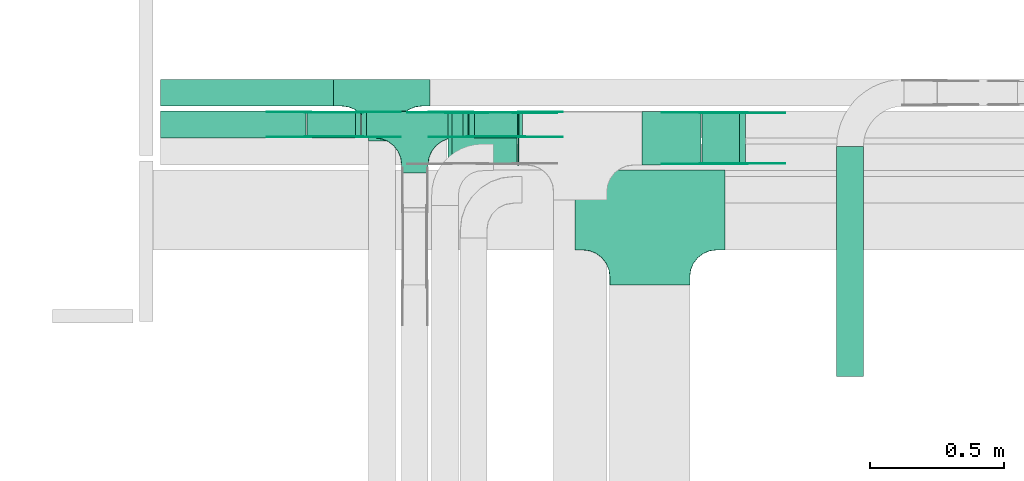
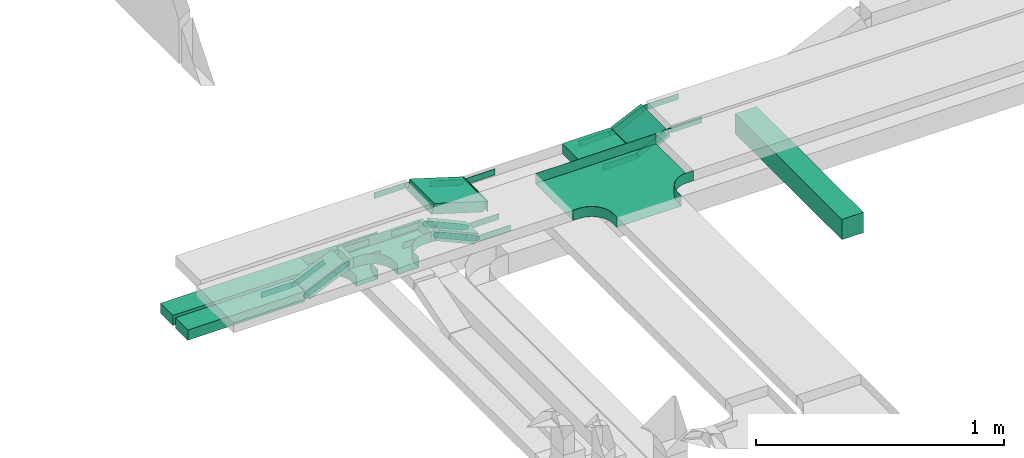
# One storey, part 7 of 19: 31 flow fittings, 11 flow segments.
"""IFC2X3 building model written with IfcOpenShell, lengths in millimetres."""

from ifc_helpers import new_model, entity, si_unit, converted_unit, derived_unit, direction, frame, frame_2d, origin, origin_2d_with_axis, place, context, subcontext, project, spatial, polyline, circle_curve, parameter, trimmed, segment, composite_curve, rectangle, outline, extrude, faceted_brep, source, transform, mapped, material, type_object, type_shapes, element, save


model = new_model("IFC2X3")

# Units and contexts
model_context = context("Model", 3, precision=0.01, world=origin(), true_north=direction((6.12303176911189e-17, 1.0)))
body_context = subcontext(model_context, "Body", "Model", "MODEL_VIEW")
ifc_project = project(units=[si_unit("LENGTHUNIT", "METRE", prefix="MILLI"), si_unit("AREAUNIT", "SQUARE_METRE"), si_unit("VOLUMEUNIT", "CUBIC_METRE"), converted_unit("PLANEANGLEUNIT", "DEGREE", entity("IfcRatioMeasure", 0.0174532925199433), si_unit("PLANEANGLEUNIT", "RADIAN"), dimensions=[0, 0, 0, 0, 0, 0, 0]), si_unit("MASSUNIT", "GRAM", prefix="KILO"), derived_unit("MASSDENSITYUNIT", [(si_unit("MASSUNIT", "GRAM", prefix="KILO"), 1), (si_unit("LENGTHUNIT", "METRE"), -3)]), derived_unit("MOMENTOFINERTIAUNIT", [(si_unit("LENGTHUNIT", "METRE"), 4)]), si_unit("TIMEUNIT", "SECOND"), si_unit("FREQUENCYUNIT", "HERTZ"), si_unit("THERMODYNAMICTEMPERATUREUNIT", "DEGREE_CELSIUS"), derived_unit("THERMALTRANSMITTANCEUNIT", [(si_unit("MASSUNIT", "GRAM", prefix="KILO"), 1), (si_unit("THERMODYNAMICTEMPERATUREUNIT", "KELVIN"), -1), (si_unit("TIMEUNIT", "SECOND"), -3)]), derived_unit("VOLUMETRICFLOWRATEUNIT", [(si_unit("LENGTHUNIT", "METRE"), 3), (si_unit("TIMEUNIT", "SECOND"), -1)]), derived_unit("MASSFLOWRATEUNIT", [(si_unit("MASSUNIT", "GRAM", prefix="KILO"), 1), (si_unit("TIMEUNIT", "SECOND"), -1)]), derived_unit("ROTATIONALFREQUENCYUNIT", [(si_unit("TIMEUNIT", "SECOND"), -1)]), si_unit("ELECTRICCURRENTUNIT", "AMPERE"), si_unit("ELECTRICVOLTAGEUNIT", "VOLT"), si_unit("POWERUNIT", "WATT"), si_unit("FORCEUNIT", "NEWTON", prefix="KILO"), si_unit("ILLUMINANCEUNIT", "LUX"), si_unit("LUMINOUSFLUXUNIT", "LUMEN"), si_unit("LUMINOUSINTENSITYUNIT", "CANDELA"), derived_unit("USERDEFINED", [(si_unit("MASSUNIT", "GRAM", prefix="KILO"), -1), (si_unit("LENGTHUNIT", "METRE"), -2), (si_unit("TIMEUNIT", "SECOND"), 3), (si_unit("LUMINOUSFLUXUNIT", "LUMEN"), 1)]), derived_unit("LINEARVELOCITYUNIT", [(si_unit("LENGTHUNIT", "METRE"), 1), (si_unit("TIMEUNIT", "SECOND"), -1)]), si_unit("PRESSUREUNIT", "PASCAL"), derived_unit("USERDEFINED", [(si_unit("LENGTHUNIT", "METRE"), -2), (si_unit("MASSUNIT", "GRAM", prefix="KILO"), 1), (si_unit("TIMEUNIT", "SECOND"), -2)]), derived_unit("LINEARFORCEUNIT", [(si_unit("MASSUNIT", "GRAM", prefix="KILO"), 1), (si_unit("LENGTHUNIT", "METRE"), 1), (si_unit("TIMEUNIT", "SECOND"), -2), (si_unit("LENGTHUNIT", "METRE"), -1)]), derived_unit("PLANARFORCEUNIT", [(si_unit("MASSUNIT", "GRAM", prefix="KILO"), 1), (si_unit("LENGTHUNIT", "METRE"), 1), (si_unit("TIMEUNIT", "SECOND"), -2), (si_unit("LENGTHUNIT", "METRE"), -2)])], contexts=[model_context])

# Site, building, storey
site_placement = place(None, frame((0.0, -0.00077364408347762, 0.0)))
site = spatial("IfcSite", under=ifc_project, at=site_placement, CompositionType="ELEMENT")
building_placement = place(site_placement, origin())
building = spatial("IfcBuilding", under=site, at=building_placement, CompositionType="ELEMENT")
storey_placement = place(building_placement, frame((0.0, 0.0, 12000.0)))
storey = spatial("IfcBuildingStorey", under=building, at=storey_placement, CompositionType="ELEMENT", Elevation=12000.0)

# Flow segments
cable_carrier_segment_type = type_object("IfcCableCarrierSegmentType", PredefinedType="CABLETRAYSEGMENT")
flow_segment_1_placement = place(storey_placement, frame((16550.9424818654, 14792.4967897, 2500.0)))
element("IfcFlowSegment", 1, at=flow_segment_1_placement, inside=storey, type_object=cable_carrier_segment_type, context=body_context, shape_type="SweptSolid", body=[
    extrude(rectangle(XDim=646.818670860271, YDim=99.9999999999989, at=frame_2d((-2.1600499167107e-12, 0.0), x_axis=(1.0, 0.0))), frame((323.409335430133, 50.0, 0.0), z_axis=(0.0, 0.0, 1.0), x_axis=(-1.0, 0.0, 0.0)), (0.0, 0.0, 1.0), 50.0000000000016),
])
flow_segment_2_placement = place(storey_placement, frame((17702.9651681534, 14673.6298749258, 2505.07528193029)))
element("IfcFlowSegment", 2, at=flow_segment_2_placement, inside=storey, type_object=cable_carrier_segment_type, context=body_context, shape_type="SweptSolid", body=[
    extrude(rectangle(XDim=50.0000000000028, YDim=99.9999999999989, at=origin_2d_with_axis()), frame((10.1684160768604, 50.0, 103.1427625712), z_axis=(0.913545457643227, 0.0, -0.406736643074393), x_axis=(0.406736643074393, 0.0, 0.913545457643227)), (0.0, 0.0, 1.0), 197.435189323302),
])
flow_segment_3_placement = place(storey_placement, frame((16550.9424818654, 14673.6298749258, 2500.0)))
element("IfcFlowSegment", 3, at=flow_segment_3_placement, inside=storey, type_object=cable_carrier_segment_type, context=body_context, shape_type="SweptSolid", body=[
    extrude(rectangle(XDim=543.455150568502, YDim=99.9999999999989, at=frame_2d((-1.08002495835535e-12, 0.0), x_axis=(1.0, 0.0))), frame((271.72757528425, 50.0, 0.0), z_axis=(0.0, 0.0, 1.0), x_axis=(-1.0, 0.0, 0.0)), (0.0, 0.0, 1.0), 49.9999999999995),
])
flow_segment_4_placement = place(storey_placement, frame((17680.803072578, 14673.6298749258, 2586.13196287297)))
element("IfcFlowSegment", 4, at=flow_segment_4_placement, inside=storey, type_object=cable_carrier_segment_type, context=body_context, shape_type="SweptSolid", body=[
    extrude(rectangle(XDim=18.6216035453551, YDim=99.9999999999989, at=frame_2d((-1.08357767203415e-12, 0.0), x_axis=(1.0, 0.0))), frame((9.31080177267646, 50.0, 0.0), z_axis=(0.0, 0.0, 1.0), x_axis=(-1.0, 0.0, 0.0)), (0.0, 0.0, 1.0), 50.0000000000016),
])
flow_segment_5_placement = place(storey_placement, frame((18573.0842066979, 14572.4967897, 2733.33230167144)))
element("IfcFlowSegment", 5, at=flow_segment_5_placement, inside=storey, type_object=cable_carrier_segment_type, context=body_context, shape_type="SweptSolid", body=[
    extrude(rectangle(XDim=49.9999999999998, YDim=155.862434681128, at=frame_2d((9.80548975348938e-13, 4.56523707725864e-13), x_axis=(0.0, 1.0))), frame((81.195125672565, 0.0, 55.5928502834292), z_axis=(0.0, 1.0, 0.0), x_axis=(-0.90630778703871, 0.0, -0.422618261736281)), (0.0, 0.0, 1.0), 200.000000000002),
])
flow_segment_6_placement = place(storey_placement, frame((17884.8247086532, 14572.4967897, 2727.85030390974)))
element("IfcFlowSegment", 6, at=flow_segment_6_placement, inside=storey, type_object=cable_carrier_segment_type, context=body_context, shape_type="SweptSolid", body=[
    extrude(rectangle(XDim=3.76271822263056, YDim=200.000000000002, at=frame_2d((-1.08291153821938e-12, 2.16715534406831e-12), x_axis=(1.0, 0.0))), frame((1.88135911131636, 100.0, 0.0), z_axis=(0.0, 0.0, 1.0), x_axis=(-1.0, 0.0, 0.0)), (0.0, 0.0, 1.0), 50.0000000000016),
])
flow_segment_7_placement = place(storey_placement, frame((17624.0602118023, 14572.4967897, 2730.5022187924)))
element("IfcFlowSegment", 7, at=flow_segment_7_placement, inside=storey, type_object=cable_carrier_segment_type, context=body_context, shape_type="SweptSolid", body=[
    extrude(rectangle(XDim=50.0000000000004, YDim=200.000000000002, at=frame_2d((0.0, 2.16715534406831e-12), x_axis=(1.0, 0.0))), frame((7.30929261783618, 100.0, 98.2063258045626), z_axis=(0.956304755965903, 0.0, -0.292371704713358), x_axis=(0.292371704713358, 0.0, 0.956304755965903)), (0.0, 0.0, 1.0), 254.124136185707),
])
flow_segment_8_placement = place(storey_placement, frame((18348.5874268759, 14572.4967897, 2727.85030390974)))
element("IfcFlowSegment", 8, at=flow_segment_8_placement, inside=storey, type_object=cable_carrier_segment_type, context=body_context, shape_type="SweptSolid", body=[
    extrude(rectangle(XDim=220.899998987963, YDim=200.000000000002, at=frame_2d((0.0, 2.16715534406831e-12), x_axis=(1.0, 0.0))), frame((110.449999493981, 100.0, 0.0), z_axis=(0.0, 0.0, 1.0), x_axis=(-1.0, 0.0, 0.0)), (0.0, 0.0, 1.0), 50.0000000000016),
])
flow_segment_9_placement = place(storey_placement, frame((19076.5152668448, 13782.4967897, 2650.0)))
element("IfcFlowSegment", 9, at=flow_segment_9_placement, inside=storey, type_object=cable_carrier_segment_type, context=body_context, shape_type="SweptSolid", body=[
    extrude(rectangle(XDim=859.000000000028, YDim=99.9999999999989, at=origin_2d_with_axis()), frame((50.0, 429.500000000015, 0.0), z_axis=(0.0, 0.0, 1.0), x_axis=(0.0, -1.0, 0.0)), (0.0, 0.0, 1.0), 99.9999999999989),
])
flow_segment_10_placement = place(storey_placement, frame((17097.9381244638, 14673.6298749258, 2505.07528193054)))
element("IfcFlowSegment", 10, at=flow_segment_10_placement, inside=storey, type_object=cable_carrier_segment_type, context=body_context, shape_type="SweptSolid", body=[
    extrude(rectangle(XDim=49.9999999999993, YDim=99.9999999999989, at=frame_2d((0.0, 0.0), x_axis=(0.0, 1.0))), frame((10.1684160768561, 50.0, 22.838636441082), z_axis=(0.913545457643292, 0.0, 0.406736643074248), x_axis=(0.0, 1.0, 0.0)), (0.0, 0.0, 1.0), 197.435189322844),
])
flow_segment_11_placement = place(storey_placement, frame((17302.1814690323, 14673.6298749258, 2586.13196287297)))
element("IfcFlowSegment", 11, at=flow_segment_11_placement, inside=storey, type_object=cable_carrier_segment_type, context=body_context, shape_type="SweptSolid", body=[
    extrude(rectangle(XDim=18.6216035457038, YDim=99.9999999999989, at=origin_2d_with_axis()), frame((9.31080177285189, 50.0, 0.0)), (0.0, 0.0, 1.0), 50.0000000000016),
])

# Flow fittings
ifc_material_1 = material()
cable_carrier_fitting_type_1 = type_object("IfcCableCarrierFittingType", PredefinedType="NOTDEFINED", material=ifc_material_1)
shared_shape_1 = source(origin(), body_context, "Body", "Brep", [
    faceted_brep([(-53.4074173710859, -124.118095489752, 25.0), (-50.0, -150.0, 25.0), (-50.0, -180.0, 25.0), (-49.1999999999934, -180.0, 25.0), (-49.1999999999926, -150.0, 25.0), (-52.6346767100545, -123.91104025367, 25.0), (-62.7046392985216, -99.6000000000037, 25.0), (-78.7236364563899, -78.7236364563991, 25.0), (-99.5999999999949, -62.7046392985315, 25.0), (-123.911040253662, -52.6346767100651, 25.0), (-150.0, -49.2000000000047, 25.0), (-180.0, -49.2000000000047, 25.0), (-180.0, -50.0, 25.0), (-150.0, -50.0, 25.0), (-124.118095489745, -53.4074173710983, 25.0), (-100.0, -63.3974596215602, 25.0), (-79.2893218813398, -79.2893218813488, 25.0), (-63.3974596215496, -100.0, 25.0), (180.0, -50.0, 25.0), (180.0, -49.2000000000047, 25.0), (150.0, -49.2000000000046, 25.0), (123.911040253717, -52.634676710066, 25.0), (99.6000000000452, -62.7046392985316, 25.0), (78.7236364564342, -78.7236364563979, 25.0), (62.7046392985581, -99.6000000000012, 25.0), (52.6346767100809, -123.911040253668, 25.0), (49.200000000007, -150.0, 25.0), (49.2000000000071, -180.0, 25.0), (50.0, -180.0, 25.0), (50.0, -150.0, 25.0), (53.4074173711136, -124.11809548975, 25.0), (63.3974596215874, -100.0, 25.0), (79.2893218813853, -79.2893218813486, 25.0), (100.0, -63.3974596215613, 25.0), (124.1180954898, -53.4074173710999, 25.0), (150.0, -50.0, 25.0), (180.0, 49.1999999999958, 25.0), (180.0, 50.0, 25.0), (-180.0, 50.0, 25.0), (-180.0, 49.1999999999958, 25.0), (-180.0, -50.0, -25.0), (-180.0, 50.0, -25.0), (180.0, 50.0, -25.0), (180.0, -50.0, -25.0), (150.0, -50.0, -25.0), (124.1180954898, -53.4074173710999, -25.0), (100.0, -63.3974596215613, -25.0), (79.2893218813853, -79.2893218813486, -25.0), (63.3974596215874, -100.0, -25.0), (53.4074173711136, -124.11809548975, -25.0), (50.0, -150.0, -25.0), (50.0, -180.0, -25.0), (-50.0, -180.0, -25.0), (-50.0, -150.0, -25.0), (-53.4074173710859, -124.118095489752, -25.0), (-63.3974596215496, -100.0, -25.0), (-79.2893218813398, -79.2893218813488, -25.0), (-100.0, -63.3974596215602, -25.0), (-124.118095489745, -53.4074173710983, -25.0), (-150.0, -50.0, -25.0), (-50.0, -150.0, -24.199999999986), (49.2000000000071, -180.0, -24.199999999986), (-49.1999999999934, -180.0, -24.199999999986), (-49.1999999999926, -150.0, -24.199999999986), (-150.0, -49.2000000000047, -24.199999999986), (-180.0, -49.2000000000047, -24.199999999986), (180.0, -49.2000000000047, -24.199999999986), (150.0, -49.2000000000047, -24.199999999986), (-180.0, 49.1999999999958, -24.199999999986), (-150.0, -50.0, -24.199999999986), (150.0, -50.0, -24.199999999986), (180.0, 49.1999999999958, -24.199999999986), (49.200000000007, -150.0, -24.199999999986), (50.0, -150.0, -24.199999999986), (-123.911040253662, -52.6346767100651, -24.199999999986), (-99.5999999999949, -62.7046392985315, -24.199999999986), (-78.7236364563899, -78.7236364563991, -24.199999999986), (-62.7046392985217, -99.6000000000036, -24.199999999986), (-52.6346767100546, -123.91104025367, -24.199999999986), (52.6346767100807, -123.911040253669, -24.199999999986), (62.7046392985577, -99.6000000000018, -24.199999999986), (78.7236364564338, -78.7236364563983, -24.199999999986), (99.6000000000446, -62.704639298532, -24.199999999986), (123.911040253716, -52.6346767100662, -24.199999999986)], [[[0, 1, 2, 3, 4, 5, 6, 7, 8, 9, 10, 11, 12, 13, 14, 15, 16, 17]], [[18, 19, 20, 21, 22, 23, 24, 25, 26, 27, 28, 29, 30, 31, 32, 33, 34, 35]], [[36, 37, 38, 39]], [[40, 41, 42, 43, 44, 45, 46, 47, 48, 49, 50, 51, 52, 53, 54, 55, 56, 57, 58, 59]], [[2, 1, 60, 53, 52]], [[3, 2, 52, 51, 28, 27, 61, 62]], [[4, 3, 62, 63]], [[11, 10, 64, 65]], [[20, 19, 66, 67]], [[39, 38, 41, 40, 12, 11, 65, 68]], [[13, 12, 40, 59, 69]], [[18, 35, 70, 44, 43]], [[19, 18, 43, 42, 37, 36, 71, 66]], [[27, 26, 72, 61]], [[29, 28, 51, 50, 73]], [[38, 37, 42, 41]], [[36, 39, 68, 71]], [[68, 65, 64, 74, 75, 76, 77, 78, 63, 62, 61, 72, 79, 80, 81, 82, 83, 67, 66, 71]], [[14, 13, 69, 59, 58]], [[58, 57, 15, 14]], [[15, 57, 56, 16]], [[0, 17, 55, 54]], [[0, 54, 53, 60, 1]], [[55, 17, 16, 56]], [[5, 4, 63, 78]], [[6, 5, 78, 77]], [[7, 6, 77, 76]], [[8, 7, 76, 75]], [[9, 8, 75, 74]], [[10, 9, 74, 64]], [[21, 20, 67, 83]], [[22, 21, 83, 82]], [[23, 22, 82, 81]], [[81, 80, 24, 23]], [[24, 80, 79, 25]], [[79, 72, 26, 25]], [[30, 29, 73, 50, 49]], [[31, 30, 49, 48]], [[31, 48, 47, 32]], [[33, 32, 47, 46]], [[45, 34, 33, 46]], [[34, 45, 44, 70, 35]]]),
])
type_shapes(cable_carrier_fitting_type_1, [shared_shape_1])
for number, where, name in (
    (12, (17377.7611527256, 14842.4967897, 2525.0), "470_DKC_S5_T"),
    (13, (17500.803072578, 14723.6298749258, 2611.13196287297), "470_DKC_S5_T"),
):
    element("IfcFlowFitting", number, at=place(storey_placement, frame(where)), inside=storey, type_object=cable_carrier_fitting_type_1, material=ifc_material_1, Name=name, context=body_context, shape_type="MappedRepresentation", body=[
        mapped(shared_shape_1, transform((0.0, 0.0, 0.0), scale=1.0)),
    ])
ifc_material_2 = material(Name="G")
cable_carrier_fitting_type_2 = type_object("IfcCableCarrierFittingType", PredefinedType="NOTDEFINED", material=ifc_material_2)
shared_shape_2 = source(origin(), body_context, "Body", "SweptSolid", [
    extrude(outline(composite_curve([segment(trimmed(circle_curve(frame_2d((-44.5901162790698, 0.0), x_axis=(1.0, 0.0)), 12.5), [parameter(90.0000000000007)], [parameter(270.0)], True, "PARAMETER"), True, "CONTINUOUS"), segment(polyline([(-44.5901162790697, -12.5), (-33.0901162790698, -12.5)]), True, "CONTINUOUS"), segment(polyline([(-33.0901162790698, -12.5), (-31.2296511627907, -14.5)]), True, "CONTINUOUS"), segment(polyline([(-31.2296511627907, -14.5), (108.90988372093, -14.5)]), True, "CONTINUOUS"), segment(polyline([(108.90988372093, -14.5), (108.90988372093, 14.5)]), True, "CONTINUOUS"), segment(polyline([(108.90988372093, 14.5), (-31.2296511627907, 14.5)]), True, "CONTINUOUS"), segment(polyline([(-31.2296511627907, 14.5), (-33.0901162790698, 12.5)]), True, "CONTINUOUS"), segment(polyline([(-33.0901162790698, 12.5), (-44.5901162790699, 12.5)]), True, "CONTINUOUS")], self_intersect=False)), frame((44.5901162790698, 0.0, 0.0), z_axis=(0.0, 0.0, -1.0), x_axis=(1.0, 0.0, 0.0)), (0.0, 0.0, -1.0), 2.0),
])
type_shapes(cable_carrier_fitting_type_2, [shared_shape_2])
for number, where, z_axis, x_axis in (
    (14, (17706.5888164119, 14678.1698749157, 2611.13196287296), (0.0, -1.0, 0.0), (-1.0, 0.0, 0.0)),
    (15, (18731.6420936605, 14577.0367896898, 2825.0), (0.0, -1.0, 0.0), (-0.906307787036605, 0.0, -0.422618261740797)),
    (16, (18576.9165710805, 14767.9567897102, 2752.85030390972), (0.0, 1.0, 0.0), (-1.0, 0.0, 0.0)),
    (17, (17879.4906296141, 14767.9567897102, 2752.85030390972), (0.0, 1.0, 0.0), (-0.956304755962822, 0.0, 0.292371704723434)),
    (18, (17900.0443724339, 14678.1698749157, 2525.0), (0.0, -1.0, 0.0), (1.0, 0.0, 0.0)),
    (19, (17295.0173287439, 14769.089874936, 2611.13196287299), (0.0, 1.0, 0.0), (1.0, 0.0, 0.0)),
    (20, (17101.5617727223, 14769.089874936, 2525.0), (0.0, 1.0, 0.0), (-1.0, 0.0, 0.0)),
):
    element("IfcFlowFitting", number, at=place(storey_placement, frame(where, z_axis=z_axis, x_axis=x_axis)), inside=storey, type_object=cable_carrier_fitting_type_2, material=ifc_material_2, context=body_context, shape_type="MappedRepresentation", body=[
        mapped(shared_shape_2, transform((0.0, 0.0, 0.0), scale=1.0)),
    ])
cable_carrier_fitting_type_3 = type_object("IfcCableCarrierFittingType", PredefinedType="NOTDEFINED", material=ifc_material_2)
shared_shape_3 = source(origin(), body_context, "Body", "SweptSolid", [
    extrude(outline(composite_curve([segment(trimmed(circle_curve(frame_2d((-44.5901162790697, 0.0), x_axis=(1.0, 0.0)), 12.5), [parameter(90.0000000000007)], [parameter(270.0)], True, "PARAMETER"), True, "CONTINUOUS"), segment(polyline([(-44.5901162790697, -12.5), (-33.0901162790697, -12.5)]), True, "CONTINUOUS"), segment(polyline([(-33.0901162790697, -12.5), (-31.2296511627907, -14.5)]), True, "CONTINUOUS"), segment(polyline([(-31.2296511627907, -14.5), (108.90988372093, -14.5)]), True, "CONTINUOUS"), segment(polyline([(108.90988372093, -14.5), (108.90988372093, 14.5)]), True, "CONTINUOUS"), segment(polyline([(108.90988372093, 14.5), (-31.2296511627907, 14.5)]), True, "CONTINUOUS"), segment(polyline([(-31.2296511627907, 14.5), (-33.0901162790698, 12.5)]), True, "CONTINUOUS"), segment(polyline([(-33.0901162790698, 12.5), (-44.5901162790699, 12.5)]), True, "CONTINUOUS")], self_intersect=False)), frame((44.5901162790697, 0.0, 0.0)), (0.0, 0.0, 1.0), 2.0),
])
type_shapes(cable_carrier_fitting_type_3, [shared_shape_3])
for number, where, z_axis, x_axis in (
    (21, (17706.5888164119, 14769.089874936, 2611.13196287296), (0.0, 1.0, 0.0), (-1.0, 0.0, 0.0)),
    (22, (18731.6420936605, 14767.9567897102, 2825.0), (0.0, 1.0, 0.0), (-0.906307787036605, 0.0, -0.422618261740797)),
    (23, (18576.9165710805, 14577.0367896898, 2752.85030390972), (0.0, -1.0, 0.0), (-1.0, 0.0, 0.0)),
    (24, (17626.2684992664, 14767.9567897102, 2830.26807837875), (0.0, 1.0, 0.0), (-1.0, 0.0, 0.0)),
    (25, (17900.0443724339, 14769.089874936, 2525.0), (0.0, 1.0, 0.0), (1.0, 0.0, 0.0)),
    (26, (17295.0173287439, 14678.1698749157, 2611.13196287299), (0.0, -1.0, 0.0), (1.0, 0.0, 0.0)),
    (27, (17101.5617727223, 14678.1698749157, 2525.0), (0.0, -1.0, 0.0), (-1.0, 0.0, 0.0)),
):
    element("IfcFlowFitting", number, at=place(storey_placement, frame(where, z_axis=z_axis, x_axis=x_axis)), inside=storey, type_object=cable_carrier_fitting_type_3, material=ifc_material_2, context=body_context, shape_type="MappedRepresentation", body=[
        mapped(shared_shape_3, transform((0.0, 0.0, 0.0), scale=1.0)),
    ])
cable_carrier_fitting_type_4 = type_object("IfcCableCarrierFittingType", PredefinedType="NOTDEFINED", material=ifc_material_2)
shared_shape_4 = source(origin(), body_context, "Body", "SweptSolid", [
    extrude(outline(composite_curve([segment(trimmed(circle_curve(frame_2d((-44.5901162790698, 0.0), x_axis=(1.0, 0.0)), 12.5), [parameter(90.0000000000007)], [parameter(270.0)], True, "PARAMETER"), True, "CONTINUOUS"), segment(polyline([(-44.5901162790697, -12.5), (-33.0901162790698, -12.5)]), True, "CONTINUOUS"), segment(polyline([(-33.0901162790698, -12.5), (-31.2296511627907, -14.5)]), True, "CONTINUOUS"), segment(polyline([(-31.2296511627907, -14.5), (108.90988372093, -14.5)]), True, "CONTINUOUS"), segment(polyline([(108.90988372093, -14.5), (108.90988372093, 14.5)]), True, "CONTINUOUS"), segment(polyline([(108.90988372093, 14.5), (-31.2296511627907, 14.5)]), True, "CONTINUOUS"), segment(polyline([(-31.2296511627907, 14.5), (-33.0901162790698, 12.5)]), True, "CONTINUOUS"), segment(polyline([(-33.0901162790698, 12.5), (-44.5901162790699, 12.5)]), True, "CONTINUOUS")], self_intersect=False)), frame((44.5901162790698, 0.0, 0.0), z_axis=(0.0, 0.0, -1.0), x_axis=(1.0, 0.0, 0.0)), (0.0, 0.0, -1.0), 2.0),
])
type_shapes(cable_carrier_fitting_type_4, [shared_shape_4])
for number, where, z_axis, x_axis in (
    (28, (17706.5888164118, 14767.089874936, 2611.13196287296), (0.0, 1.0, 0.0), (0.913545457641225, 0.0, -0.40673664307889)),
    (29, (18731.6420936605, 14765.9567897102, 2825.0), (0.0, 1.0, 0.0), (1.0, 0.0, 0.0)),
    (30, (18576.9165710805, 14579.0367896898, 2752.85030390972), (0.0, -1.0, 0.0), (0.906307787036631, 0.0, 0.42261826174074)),
    (31, (17626.2684992664, 14765.9567897102, 2830.26807837874), (0.0, 1.0, 0.0), (0.956304755964475, 0.0, -0.29237170471803)),
    (32, (17900.0443724339, 14767.089874936, 2525.0), (0.0, 1.0, 0.0), (-0.913545457641238, 0.0, 0.406736643078861)),
    (33, (17295.0173287439, 14680.1698749157, 2611.13196287299), (0.0, -1.0, 0.0), (-0.913545457641238, 0.0, -0.406736643078861)),
    (34, (17101.5617727223, 14680.1698749157, 2525.0), (0.0, -1.0, 0.0), (0.913545457641291, 0.0, 0.406736643078741)),
):
    element("IfcFlowFitting", number, at=place(storey_placement, frame(where, z_axis=z_axis, x_axis=x_axis)), inside=storey, type_object=cable_carrier_fitting_type_4, material=ifc_material_2, context=body_context, shape_type="MappedRepresentation", body=[
        mapped(shared_shape_4, transform((0.0, 0.0, 0.0), scale=1.0)),
    ])
cable_carrier_fitting_type_5 = type_object("IfcCableCarrierFittingType", PredefinedType="NOTDEFINED", material=ifc_material_2)
shared_shape_5 = source(origin(), body_context, "Body", "SweptSolid", [
    extrude(outline(composite_curve([segment(trimmed(circle_curve(frame_2d((-44.5901162790697, 0.0), x_axis=(1.0, 0.0)), 12.5), [parameter(90.0000000000007)], [parameter(270.0)], True, "PARAMETER"), True, "CONTINUOUS"), segment(polyline([(-44.5901162790697, -12.5), (-33.0901162790697, -12.5)]), True, "CONTINUOUS"), segment(polyline([(-33.0901162790697, -12.5), (-31.2296511627907, -14.5)]), True, "CONTINUOUS"), segment(polyline([(-31.2296511627907, -14.5), (108.90988372093, -14.5)]), True, "CONTINUOUS"), segment(polyline([(108.90988372093, -14.5), (108.90988372093, 14.5)]), True, "CONTINUOUS"), segment(polyline([(108.90988372093, 14.5), (-31.2296511627907, 14.5)]), True, "CONTINUOUS"), segment(polyline([(-31.2296511627907, 14.5), (-33.0901162790698, 12.5)]), True, "CONTINUOUS"), segment(polyline([(-33.0901162790698, 12.5), (-44.5901162790699, 12.5)]), True, "CONTINUOUS")], self_intersect=False)), frame((44.5901162790697, 0.0, 0.0)), (0.0, 0.0, 1.0), 2.0),
])
type_shapes(cable_carrier_fitting_type_5, [shared_shape_5])
for number, where, z_axis, x_axis in (
    (35, (17706.5888164118, 14680.1698749157, 2611.13196287296), (0.0, -1.0, 0.0), (0.913545457641225, 0.0, -0.40673664307889)),
    (36, (18731.6420936605, 14579.0367896899, 2825.0), (0.0, -1.0, 0.0), (1.0, 0.0, 0.0)),
    (37, (18576.9165710805, 14765.9567897102, 2752.85030390972), (0.0, 1.0, 0.0), (0.906307787036631, 0.0, 0.42261826174074)),
    (38, (17879.4906296141, 14765.9567897102, 2752.85030390973), (0.0, 1.0, 0.0), (1.0, 0.0, 0.0)),
    (39, (17900.0443724339, 14680.1698749157, 2525.0), (0.0, -1.0, 0.0), (-0.913545457641238, 0.0, 0.406736643078861)),
    (40, (17295.0173287439, 14767.089874936, 2611.13196287299), (0.0, 1.0, 0.0), (-0.913545457641238, 0.0, -0.406736643078861)),
    (41, (17101.5617727223, 14767.089874936, 2525.0), (0.0, 1.0, 0.0), (0.913545457641291, 0.0, 0.406736643078741)),
):
    element("IfcFlowFitting", number, at=place(storey_placement, frame(where, z_axis=z_axis, x_axis=x_axis)), inside=storey, type_object=cable_carrier_fitting_type_5, material=ifc_material_2, context=body_context, shape_type="MappedRepresentation", body=[
        mapped(shared_shape_5, transform((0.0, 0.0, 0.0), scale=1.0)),
    ])
cable_carrier_fitting_type_6 = type_object("IfcCableCarrierFittingType", PredefinedType="NOTDEFINED", material=ifc_material_1)
shared_shape_6 = source(origin(), body_context, "Body", "Brep", [
    faceted_brep([(-153.407417371086, -224.118095489753, 25.0), (-150.0, -250.0, 25.0), (-150.0, -280.0, 25.0), (-149.199999999993, -280.0, 25.0), (-149.199999999993, -250.0, 25.0), (-152.634676710055, -223.911040253671, 25.0), (-162.704639298522, -199.600000000004, 25.0), (-178.723636456391, -178.7236364564, 25.0), (-199.599999999996, -162.704639298532, 25.0), (-223.911040253663, -152.634676710066, 25.0), (-250.0, -149.200000000004, 25.0), (-280.0, -149.200000000004, 25.0), (-280.0, -150.0, 25.0), (-250.0, -150.0, 25.0), (-224.118095489745, -153.407417371099, 25.0), (-200.0, -163.397459621561, 25.0), (-179.28932188134, -179.289321881349, 25.0), (-163.39745962155, -200.0, 25.0), (280.0, -150.0, 25.0), (280.0, -149.200000000004, 25.0), (250.0, -149.200000000007, 25.0), (223.911040253719, -152.634676710068, 25.0), (199.600000000048, -162.704639298534, 25.0), (178.723636456437, -178.7236364564, 25.0), (162.70463929856, -199.600000000004, 25.0), (152.634676710083, -223.91104025367, 25.0), (149.200000000009, -250.0, 25.0), (149.200000000007, -280.0, 25.0), (150.0, -280.0, 25.0), (150.0, -250.0, 25.0), (153.407417371116, -224.118095489752, 25.0), (163.39745962159, -200.0, 25.0), (179.289321881388, -179.289321881351, 25.0), (200.0, -163.397459621564, 25.0), (224.118095489802, -153.407417371102, 25.0), (250.0, -150.0, 25.0), (280.0, 149.199999999995, 25.0), (280.0, 150.0, 25.0), (-280.0, 150.0, 25.0), (-280.0, 149.199999999995, 25.0), (-280.0, -150.0, -25.0), (-280.0, 150.0, -25.0), (280.0, 150.0, -25.0), (280.0, -150.0, -25.0), (250.0, -150.0, -25.0), (224.118095489802, -153.407417371102, -25.0), (200.0, -163.397459621564, -25.0), (179.289321881388, -179.289321881351, -25.0), (163.39745962159, -200.0, -25.0), (153.407417371116, -224.118095489752, -25.0), (150.0, -250.0, -25.0), (150.0, -280.0, -25.0), (-150.0, -280.0, -25.0), (-150.0, -250.0, -25.0), (-153.407417371086, -224.118095489753, -25.0), (-163.39745962155, -200.0, -25.0), (-179.28932188134, -179.289321881349, -25.0), (-200.0, -163.397459621561, -25.0), (-224.118095489745, -153.407417371099, -25.0), (-250.0, -150.0, -25.0), (-150.0, -250.0, -24.199999999986), (149.200000000007, -280.0, -24.199999999986), (-149.199999999993, -280.0, -24.199999999986), (-149.199999999993, -250.0, -24.199999999986), (-250.0, -149.200000000004, -24.199999999986), (-280.0, -149.200000000004, -24.199999999986), (280.0, -149.200000000004, -24.199999999986), (250.0, -149.200000000004, -24.199999999986), (-280.0, 149.199999999995, -24.199999999986), (-250.0, -150.0, -24.199999999986), (250.0, -150.0, -24.199999999986), (280.0, 149.199999999995, -24.199999999986), (149.200000000009, -250.0, -24.199999999986), (150.0, -250.0, -24.199999999986), (-223.911040253663, -152.634676710066, -24.199999999986), (-199.599999999996, -162.704639298532, -24.199999999986), (-178.723636456391, -178.7236364564, -24.199999999986), (-162.704639298522, -199.600000000004, -24.199999999986), (-152.634676710055, -223.911040253671, -24.199999999986), (152.634676710083, -223.911040253671, -24.199999999986), (162.70463929856, -199.600000000004, -24.199999999986), (178.723636456436, -178.723636456401, -24.199999999986), (199.600000000047, -162.704639298534, -24.199999999986), (223.911040253719, -152.634676710069, -24.199999999986)], [[[0, 1, 2, 3, 4, 5, 6, 7, 8, 9, 10, 11, 12, 13, 14, 15, 16, 17]], [[18, 19, 20, 21, 22, 23, 24, 25, 26, 27, 28, 29, 30, 31, 32, 33, 34, 35]], [[36, 37, 38, 39]], [[40, 41, 42, 43, 44, 45, 46, 47, 48, 49, 50, 51, 52, 53, 54, 55, 56, 57, 58, 59]], [[2, 1, 60, 53, 52]], [[3, 2, 52, 51, 28, 27, 61, 62]], [[4, 3, 62, 63]], [[11, 10, 64, 65]], [[20, 19, 66, 67]], [[39, 38, 41, 40, 12, 11, 65, 68]], [[13, 12, 40, 59, 69]], [[18, 35, 70, 44, 43]], [[19, 18, 43, 42, 37, 36, 71, 66]], [[27, 26, 72, 61]], [[29, 28, 51, 50, 73]], [[38, 37, 42, 41]], [[36, 39, 68, 71]], [[68, 65, 64, 74, 75, 76, 77, 78, 63, 62, 61, 72, 79, 80, 81, 82, 83, 67, 66, 71]], [[14, 13, 69, 59, 58]], [[58, 57, 15, 14]], [[15, 57, 56, 16]], [[0, 17, 55, 54]], [[0, 54, 53, 60, 1]], [[55, 17, 16, 56]], [[5, 4, 63, 78]], [[6, 5, 78, 77]], [[7, 6, 77, 76]], [[8, 7, 76, 75]], [[9, 8, 75, 74]], [[10, 9, 74, 64]], [[21, 20, 67, 83]], [[22, 21, 83, 82]], [[23, 22, 82, 81]], [[81, 80, 24, 23]], [[24, 80, 79, 25]], [[79, 72, 26, 25]], [[30, 29, 73, 50, 49]], [[31, 30, 49, 48]], [[31, 48, 47, 32]], [[33, 32, 47, 46]], [[45, 34, 33, 46]], [[34, 45, 44, 70, 35]]]),
])
type_shapes(cable_carrier_fitting_type_6, [shared_shape_6])
flow_fitting_placement = place(storey_placement, frame((18378.5368087494, 14405.0, 2825.0)))
element("IfcFlowFitting", 42, at=flow_fitting_placement, inside=storey, type_object=cable_carrier_fitting_type_6, material=ifc_material_1, Name="470_DKC_S5_T", context=body_context, shape_type="MappedRepresentation", body=[
    mapped(shared_shape_6, transform((0.0, 0.0, 0.0), scale=1.0)),
])

save(model, "model.ifc")
